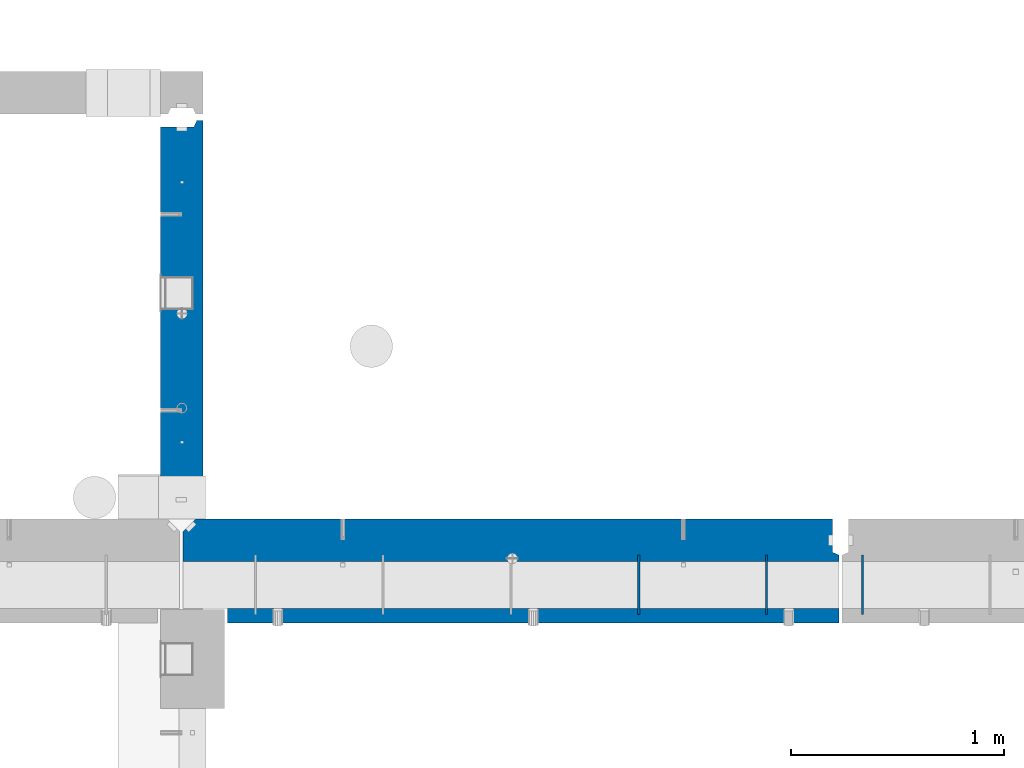
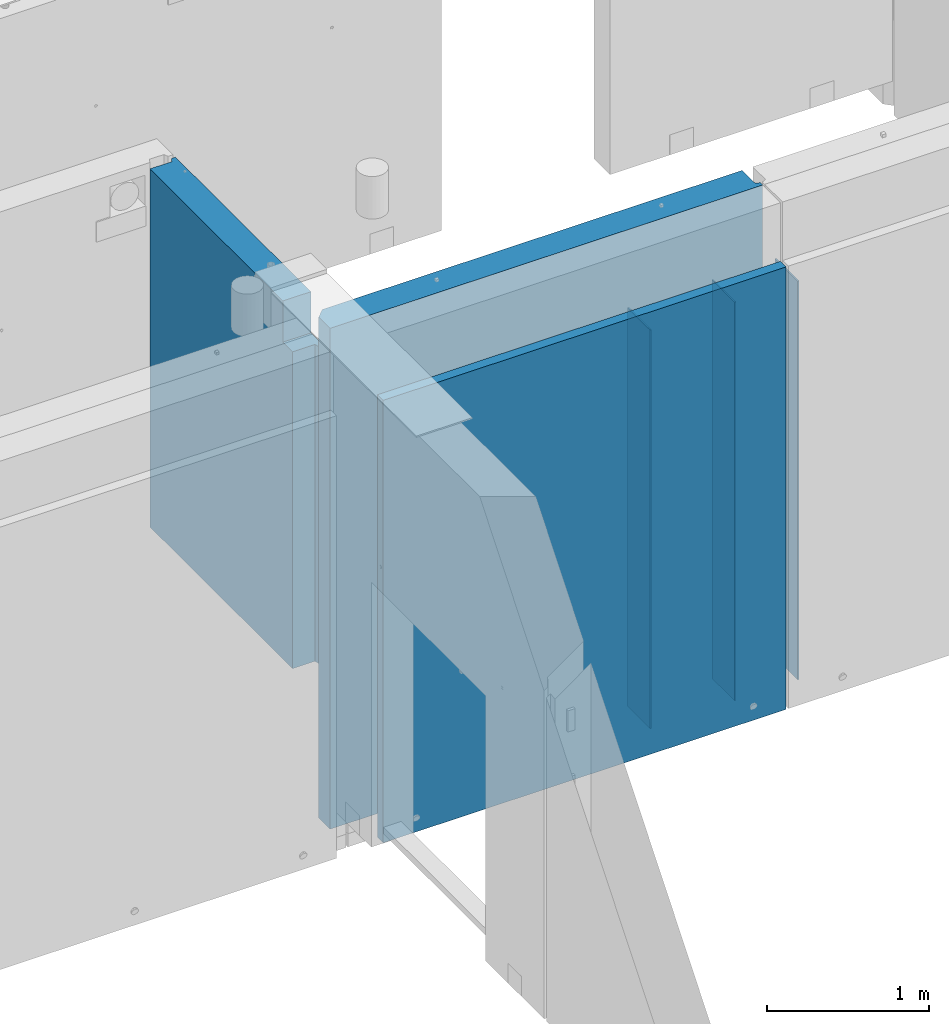
# One storey, part 173 of 264: 6 walls, 3 elements without a shape of their own.
"""IFC2X3 building model written with IfcOpenShell, lengths in millimetres."""

import ifcopenshell
import ifcopenshell.guid

model = None  # the IFC model being written
_history = None  # IfcOwnerHistory: only IFC2X3 demands one
_inside = {}  # id of a spatial element -> (the spatial element, [elements in it])
_under = {}  # id of a project, library or spatial element -> (it, [spatial elements below it])
_declared = {}  # id of a project -> (the project, [libraries it declares])
_typed = {}  # id of a type object -> (the type object, [elements of that type])
_made_of = {}  # id of a material, layer set ... -> (it, [elements and type objects made of it])


def new_model(schema):
    """Start an empty IFC model of exactly this schema.

    Asked for "IFC4X3", IfcOpenShell would pick the latest addendum, in which some entities
    have other attributes; the version numbers below select the first issue.
    IFC2X3 requires an IfcOwnerHistory on every rooted entity: one is made here for all.
    """
    global model, _history
    if schema == "IFC4X3":
        model = ifcopenshell.file(schema_version=(4, 3, 0, 0))
    else:
        model = ifcopenshell.file(schema=schema)
    _inside.clear()
    _under.clear()
    _declared.clear()
    _typed.clear()
    _made_of.clear()
    _history = None
    if model.schema == "IFC2X3":
        org = make("IfcOrganization", Name="unknown")
        user = make(
            "IfcPersonAndOrganization",
            ThePerson=make("IfcPerson", FamilyName="unknown"),
            TheOrganization=org,
        )
        app = make(
            "IfcApplication",
            ApplicationDeveloper=org,
            Version="unknown",
            ApplicationFullName="unknown",
            ApplicationIdentifier="unknown",
        )
        _history = make(
            "IfcOwnerHistory",
            OwningUser=user,
            OwningApplication=app,
            ChangeAction="ADDED",
            CreationDate=0,
        )
    return model


def make(cls, **values):
    """One entity of the class cls with the attributes given. An attribute that is None is left unset."""
    return model.create_entity(
        cls, **{name: value for name, value in values.items() if value is not None}
    )


def rooted(cls, **values):
    """An entity with a GlobalId (a new one), such as an element, a storey or a relation."""
    return make(cls, GlobalId=ifcopenshell.guid.new(), OwnerHistory=_history, **values)


def si_unit(unit_type, name, prefix=None):
    """IfcSIUnit, for example si_unit("LENGTHUNIT", "METRE", prefix="MILLI")."""
    return make("IfcSIUnit", UnitType=unit_type, Prefix=prefix, Name=name)


def assignment(units):
    """IfcUnitAssignment: the units of a project."""
    return None if units is None else make("IfcUnitAssignment", Units=units)


def point(xyz):
    """IfcCartesianPoint."""
    return None if xyz is None else make("IfcCartesianPoint", Coordinates=xyz)


def direction(xyz):
    """IfcDirection."""
    return None if xyz is None else make("IfcDirection", DirectionRatios=xyz)


def frame(location, z_axis=None, x_axis=None):
    """IfcAxis2Placement3D, a coordinate frame: its origin and axes. An axis left out is left unset."""
    return make(
        "IfcAxis2Placement3D",
        Location=point(location),
        Axis=direction(z_axis),
        RefDirection=direction(x_axis),
    )


def origin_with_axes():
    """The frame at (0, 0, 0) with the z axis (0, 0, 1) and the x axis (1, 0, 0) written out."""
    return frame((0.0, 0.0, 0.0), z_axis=(0.0, 0.0, 1.0), x_axis=(1.0, 0.0, 0.0))


def place(relative_to, where):
    """IfcLocalPlacement: puts the frame where relative to a parent placement (None: the world)."""
    return make(
        "IfcLocalPlacement", PlacementRelTo=relative_to, RelativePlacement=where
    )


def context(
    kind, dimensions, precision=None, world=None, true_north=None, identifier=None
):
    """IfcGeometricRepresentationContext, for example the 3D "Model" context."""
    return make(
        "IfcGeometricRepresentationContext",
        ContextIdentifier=identifier,
        ContextType=kind,
        CoordinateSpaceDimension=dimensions,
        Precision=precision,
        WorldCoordinateSystem=world,
        TrueNorth=true_north,
    )


def subcontext(parent, identifier, kind, view, scale=None):
    """IfcGeometricRepresentationSubContext, for example "Body" below "Model"."""
    return make(
        "IfcGeometricRepresentationSubContext",
        ContextIdentifier=identifier,
        ContextType=kind,
        ParentContext=parent,
        TargetScale=scale,
        TargetView=view,
    )


def project(units=None, contexts=None):
    """IfcProject with its units and contexts."""
    return rooted(
        "IfcProject",
        Name="project",
        RepresentationContexts=contexts,
        UnitsInContext=assignment(units),
    )


def spatial(cls, under=None, at=None, **own):
    """A site, building, storey or space (cls), placed at a placement, below another one or the project."""
    s = rooted(cls, ObjectPlacement=at, **own)
    if under is not None:
        _under.setdefault(under.id(), (under, []))[1].append(s)
    return s


def faces_of(points, faces, orient=None, outer=None):
    """IfcFace entities. A face is a list of loops; a loop is a list of indices into points, from 0.

    orient and outer hold one flag for each loop. By default every Orientation is true, the
    first loop of a face is its IfcFaceOuterBound and the others are IfcFaceBound.
    """
    made = []
    for i, loops in enumerate(faces):
        bounds = []
        for j, loop in enumerate(loops):
            is_outer = j == 0 if outer is None else outer[i][j]
            bounds.append(
                make(
                    "IfcFaceOuterBound" if is_outer else "IfcFaceBound",
                    Bound=make("IfcPolyLoop", Polygon=[points[k] for k in loop]),
                    Orientation=True if orient is None else orient[i][j],
                )
            )
        made.append(make("IfcFace", Bounds=bounds))
    return made


def faceted_brep(points, faces, orient=None, outer=None, voids=None):
    """IfcFacetedBrep: a solid bounded by flat faces; with voids (closed shells), ...WithVoids."""
    shared = [point(p) for p in points]
    hull = make("IfcClosedShell", CfsFaces=faces_of(shared, faces, orient, outer))
    if voids is None:
        return make("IfcFacetedBrep", Outer=hull)
    return make(
        "IfcFacetedBrepWithVoids",
        Outer=hull,
        Voids=[
            make(cls, CfsFaces=faces_of(shared, fs, o, b)) for cls, fs, o, b in voids
        ],
    )


def shape(context_of_items, identifier, shape_type, items):
    """IfcShapeRepresentation: the items that make up one representation, for example the "Body"."""
    return make(
        "IfcShapeRepresentation",
        ContextOfItems=context_of_items,
        RepresentationIdentifier=identifier,
        RepresentationType=shape_type,
        Items=items,
    )


def material(Name=None, Category=None):
    """IfcMaterial."""
    return make("IfcMaterial", Name=Name, Category=Category)


def made_of(thing, what):
    """Note that an element or type object is made of a material, layer set ...; save() writes the relation."""
    if what is not None:
        _made_of.setdefault(what.id(), (what, []))[1].append(thing)
    return thing


def type_object(cls, material=None, **own):
    """A type object (cls), such as IfcWallType, which elements share."""
    return made_of(rooted(cls, **own), material)


def element(
    cls,
    number,
    at=None,
    inside=None,
    cuts=None,
    type_object=None,
    material=None,
    context=None,
    identifier="Body",
    shape_type=None,
    held_by="IfcProductDefinitionShape",
    body=None,
    shapes=None,
    **own,
):
    """One element of the class cls, such as IfcWall. Its Tag is "e" and its number.

    at: its placement. inside: the storey or other place that contains it. cuts: it is an
    opening in that element (IfcRelVoidsElement). A single representation is given by context,
    identifier, shape_type and body (its items); several are given by shapes. held_by: the class
    of the entity that holds the representations. save() writes the other relations.
    """
    e = rooted(cls, Tag="e%d" % number, ObjectPlacement=at, **own)
    if body is not None:
        shapes = [shape(context, identifier, shape_type, body)]
    if shapes is not None:
        e.Representation = make(held_by, Representations=shapes)
    if inside is not None:
        _inside.setdefault(inside.id(), (inside, []))[1].append(e)
    if cuts is not None:
        rooted(
            "IfcRelVoidsElement", RelatingBuildingElement=cuts, RelatedOpeningElement=e
        )
    if type_object is not None:
        _typed.setdefault(type_object.id(), (type_object, []))[1].append(e)
    return made_of(e, material)


def aggregate(whole, parts):
    """IfcRelAggregates: a whole, such as a stair, and the parts it consists of."""
    return rooted("IfcRelAggregates", RelatingObject=whole, RelatedObjects=parts)


def save(model, path):
    """Write the relations noted so far, then the file.

    IfcRelAggregates (storeys below a building ...), IfcRelContainedInSpatialStructure (elements
    in a storey), IfcRelDefinesByType, IfcRelAssociatesMaterial and IfcRelDeclares: one each for
    every whole, place, type object, material and project.
    """
    for whole, parts in _under.values():
        aggregate(whole, parts)
    for where, things in _inside.values():
        rooted(
            "IfcRelContainedInSpatialStructure",
            RelatedElements=things,
            RelatingStructure=where,
        )
    for kind, things in _typed.values():
        rooted("IfcRelDefinesByType", RelatedObjects=things, RelatingType=kind)
    for what, things in _made_of.values():
        rooted("IfcRelAssociatesMaterial", RelatedObjects=things, RelatingMaterial=what)
    for by, libraries in _declared.values():
        rooted("IfcRelDeclares", RelatingContext=by, RelatedDefinitions=libraries)
    model.write(path)


model = new_model("IFC2X3")

# Units and contexts
model_context = context("Model", 3, precision=1e-05, world=origin_with_axes())
body_context = subcontext(model_context, "Body", "Model", "MODEL_VIEW")
ifc_project = project(units=[si_unit("LENGTHUNIT", "METRE", prefix="MILLI"), si_unit("AREAUNIT", "SQUARE_METRE"), si_unit("VOLUMEUNIT", "CUBIC_METRE"), si_unit("MASSUNIT", "GRAM", prefix="KILO"), si_unit("TIMEUNIT", "SECOND"), si_unit("PLANEANGLEUNIT", "RADIAN"), si_unit("SOLIDANGLEUNIT", "STERADIAN"), si_unit("THERMODYNAMICTEMPERATUREUNIT", "DEGREE_CELSIUS"), si_unit("LUMINOUSINTENSITYUNIT", "LUMEN")], contexts=[model_context])

# Site, building, storey
site_placement = place(None, origin_with_axes())
site = spatial("IfcSite", under=ifc_project, at=site_placement, CompositionType="ELEMENT")
building_placement = place(site_placement, origin_with_axes())
building = spatial("IfcBuilding", under=site, at=building_placement, CompositionType="ELEMENT")
storey_placement = place(building_placement, origin_with_axes())
storey = spatial("IfcBuildingStorey", under=building, at=storey_placement, Name="K", CompositionType="ELEMENT", Elevation=0.0)

# Assembly, walls
assembly_1_placement = place(storey_placement, origin_with_axes())
assembly_1 = element("IfcElementAssembly", 1, at=assembly_1_placement, inside=storey, AssemblyPlace="NOTDEFINED", PredefinedType="REINFORCEMENT_UNIT")
ifc_material_1 = material(Name="Undefined")
wall_type_1 = type_object("IfcWallType", PredefinedType="NOTDEFINED")
wall_1_placement = place(assembly_1_placement, frame((30755.0062229193, 12730.0010506694, 79360.0), z_axis=(0.0, 0.0, 1.0), x_axis=(0.0, 1.0, 0.0)))
wall_1 = element("IfcWall", 2, at=wall_1_placement, type_object=wall_type_1, material=ifc_material_1, Name="(PD)", context=body_context, shape_type="Brep", body=[
    faceted_brep([(0.0, 4.99999999999909, -1500.0), (0.0, 4.99999999999909, 1500.0), (280.000000000024, 5.0, 1500.0), (280.000000000024, 5.0, -1500.0), (0.0, -5.00000000000091, 1500.0), (280.000000000025, -5.0, 1500.0), (0.0, -5.00000000000091, -1500.0), (280.000000000025, -5.0, -1500.0)], [[[0, 1, 2, 3]], [[1, 4, 5, 2]], [[4, 6, 7, 5]], [[6, 0, 3, 7]], [[5, 7, 3, 2]], [[6, 4, 1, 0]]]),
])
wall_2_placement = place(assembly_1_placement, frame((31355.0062229193, 12730.0010506694, 79360.0), z_axis=(0.0, 0.0, 1.0), x_axis=(0.0, 1.0, 0.0)))
wall_2 = element("IfcWall", 3, at=wall_2_placement, type_object=wall_type_1, material=ifc_material_1, Name="(PD)", context=body_context, shape_type="Brep", body=[
    faceted_brep([(0.0, 4.99999999999909, -1500.0), (0.0, 4.99999999999909, 1500.0), (280.000000000024, 5.0, 1500.0), (280.000000000024, 5.0, -1500.0), (0.0, -5.00000000000091, 1500.0), (280.000000000025, -5.0, 1500.0), (0.0, -5.00000000000091, -1500.0), (280.000000000025, -5.0, -1500.0)], [[[0, 1, 2, 3]], [[1, 4, 5, 2]], [[4, 6, 7, 5]], [[6, 0, 3, 7]], [[5, 7, 3, 2]], [[6, 4, 1, 0]]]),
])

# Assembly, wall
assembly_2_placement = place(storey_placement, origin_with_axes())
assembly_2 = element("IfcElementAssembly", 4, at=assembly_2_placement, inside=storey, AssemblyPlace="NOTDEFINED", PredefinedType="REINFORCEMENT_UNIT")
wall_3_placement = place(assembly_2_placement, frame((31805.0062229193, 12730.0010506694, 79360.0), z_axis=(0.0, 0.0, 1.0), x_axis=(0.0, 1.0, 0.0)))
wall_3 = element("IfcWall", 5, at=wall_3_placement, type_object=wall_type_1, material=ifc_material_1, Name="(PD)", context=body_context, shape_type="Brep", body=[
    faceted_brep([(0.0, 4.99999999999909, -1500.0), (0.0, 4.99999999999909, 1500.0), (280.000000000024, 5.0, 1500.0), (280.000000000024, 5.0, -1500.0), (0.0, -5.00000000000091, 1500.0), (280.000000000025, -5.0, 1500.0), (0.0, -5.00000000000091, -1500.0), (280.000000000025, -5.0, -1500.0)], [[[0, 1, 2, 3]], [[1, 4, 5, 2]], [[4, 6, 7, 5]], [[6, 0, 3, 7]], [[5, 7, 3, 2]], [[6, 4, 1, 0]]]),
])
aggregate(assembly_2, [wall_3])

# Wall
ifc_material_2 = material(Name="CONCRETE/C30/37")
wall_type_2 = type_object("IfcWallType", PredefinedType="NOTDEFINED")
wall_4_placement = place(assembly_1_placement, frame((31695.0024573137, 12725.0018965848, 79365.0), z_axis=(0.0, 0.0, 1.0), x_axis=(-1.0, 3.00000001838171e-08, 0.0)))
wall_4 = element("IfcWall", 6, at=wall_4_placement, type_object=wall_type_2, material=ifc_material_2, context=body_context, shape_type="Brep", body=[
    faceted_brep([(0.0, 35.0, -1665.0), (0.0, 35.0, 1665.0), (2870.00245731375, 35.0, 1665.0), (2870.00245731375, 35.0, -1665.0), (0.0, -35.0, 1665.0), (2870.00245731375, -35.0, 1665.0), (0.0, -35.0, -1665.0), (2870.00245731375, -35.0, -1665.0)], [[[0, 1, 2, 3]], [[1, 4, 5, 2]], [[4, 6, 7, 5]], [[6, 0, 3, 7]], [[5, 7, 3, 2]], [[6, 4, 1, 0]]]),
])

# Assembly, wall
assembly_3_placement = place(storey_placement, origin_with_axes())
assembly_3 = element("IfcElementAssembly", 7, at=assembly_3_placement, inside=storey, AssemblyPlace="NOTDEFINED", PredefinedType="REINFORCEMENT_UNIT")
ifc_material_3 = material(Name="CONCRETE/C25/30")
wall_type_3 = type_object("IfcWallType", PredefinedType="NOTDEFINED")
wall_5_placement = place(assembly_3_placement, frame((28610.0, 13179.9996249472, 80122.5), z_axis=(0.0, 0.0, 1.0), x_axis=(0.0, 1.0, 0.0)))
wall_5 = element("IfcWall", 8, at=wall_5_placement, type_object=wall_type_3, material=ifc_material_3, context=body_context, shape_type="Brep", body=[
    faceted_brep([(200.003751740087, -100.0, 1347.5), (200.003751740087, 100.0, 1347.5), (200.003746719885, 100.0, 1337.5), (200.003746719885, -100.0, 1337.5), (80.0022716375479, 100.0, -1347.5), (80.0022716375479, -60.0, -1347.5), (80.0022716375479, -60.0, 1037.5), (80.0022716375479, 100.0, 1037.5), (30.0022716375479, -70.0, -1347.5), (30.0022716375479, -70.0, 1037.5), (1840.00037505278, 100.0, -1347.5), (1840.00037505278, -57.0, -1347.5), (1870.00037505278, -70.0000000000036, -1347.5), (1870.00037505278, -100.0, -1347.5), (30.0022716375479, -100.0, -1347.5), (1840.00037505278, -57.0, 1347.5), (1840.00037505278, 100.0, 1347.5), (1870.00037505278, -70.0000000000036, 1347.5), (1870.00037505278, -100.0, 1347.5), (200.003746719885, -100.0, 1037.5), (30.0022716375479, -100.0, 1037.5), (200.003746719885, 100.0, 1037.5)], [[[0, 1, 2, 3]], [[4, 5, 6, 7]], [[5, 8, 9, 6]], [[4, 10, 11, 12, 13, 14, 8, 5]], [[15, 11, 10, 16]], [[17, 12, 11, 15]], [[18, 13, 12, 17]], [[19, 20, 14, 13, 18, 0, 3]], [[8, 14, 20, 9]], [[19, 21, 7, 6, 9, 20]], [[3, 2, 21, 19]], [[16, 10, 4, 7, 21, 2, 1]], [[18, 17, 15, 16, 1, 0]]]),
])
aggregate(assembly_3, [wall_5])

# Wall
wall_type_4 = type_object("IfcWallType", PredefinedType="NOTDEFINED")
wall_6_placement = place(assembly_1_placement, frame((31695.0024573137, 13080.0018965848, 79585.0), z_axis=(0.0, 0.0, 1.0), x_axis=(-1.0, 3.00000001838171e-08, 0.0)))
wall_6 = element("IfcWall", 9, at=wall_6_placement, type_object=wall_type_4, material=ifc_material_3, context=body_context, shape_type="Brep", body=[
    faceted_brep([(30.0, 57.0, 1885.0), (30.0, 57.0, -1885.0), (30.0, -100.0, -1885.0), (30.0, -100.0, 1885.0), (0.0, 70.0, 1885.0), (0.0, 70.0, -1885.0), (3020.00245731375, -100.0, 1885.0), (3020.00245731375, -100.0, -1885.0), (3080.00245731375, -40.0, -1885.0), (3080.00245731375, -40.0, 1885.0), (3080.00245731375, 100.0, -1885.0), (3080.00245731375, 100.0, 1885.0), (0.0, 100.0, -1885.0), (0.0, 100.0, 1885.0)], [[[0, 1, 2, 3]], [[4, 5, 1, 0]], [[6, 7, 8, 9]], [[10, 11, 9, 8]], [[12, 13, 11, 10]], [[3, 6, 9, 11, 13, 4, 0]], [[7, 6, 3, 2]], [[12, 10, 8, 7, 2, 1, 5]], [[13, 12, 5, 4]]]),
])

aggregate(assembly_1, [wall_1, wall_2, wall_4, wall_6])

save(model, "model.ifc")
